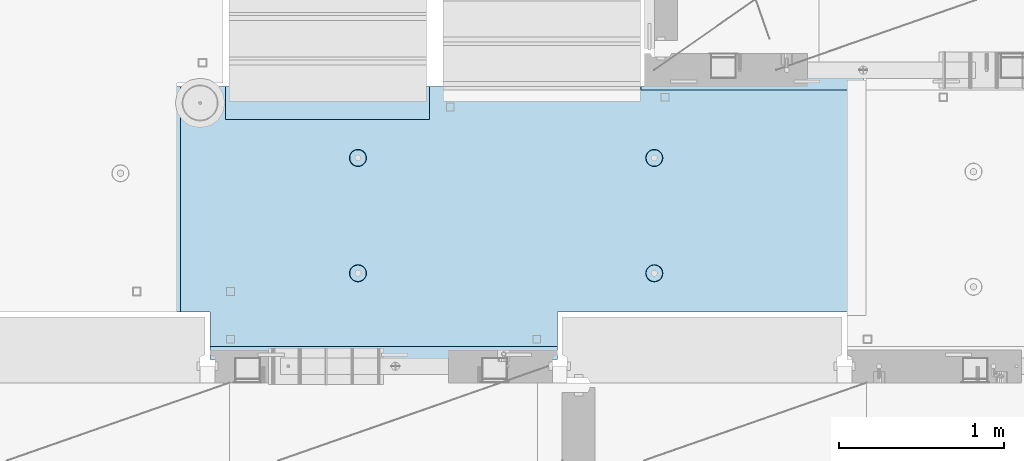
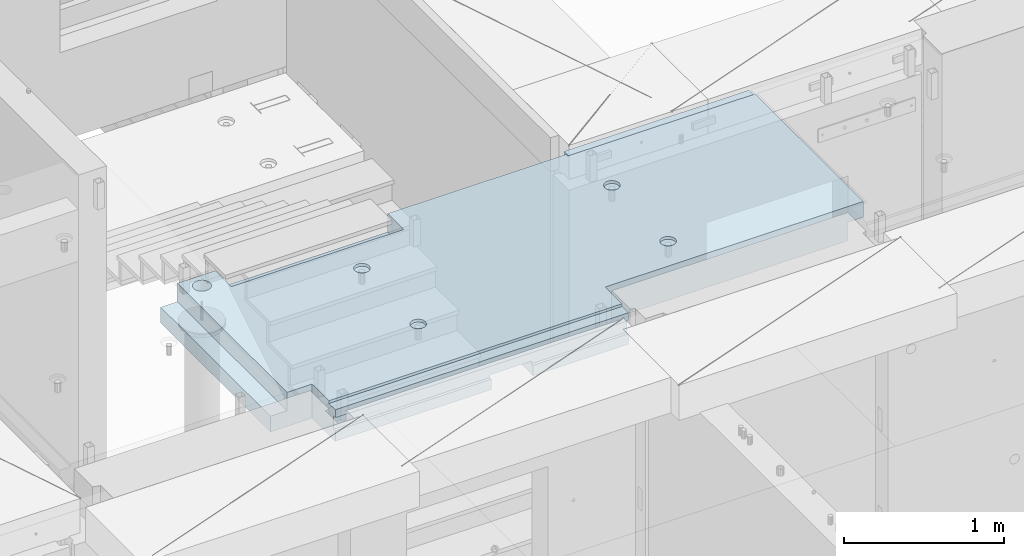
# One storey, part 206 of 352: 1 slab, 1 element without a shape of its own.
"""IFC2X3 building model written with IfcOpenShell, lengths in millimetres."""

from ifc_helpers import new_model, si_unit, frame, origin_with_axes, place, context, subcontext, project, spatial, faceted_brep, material, type_object, element, aggregate, save


model = new_model("IFC2X3")

# Units and contexts
model_context = context("Model", 3, precision=1e-05, world=origin_with_axes())
body_context = subcontext(model_context, "Body", "Model", "MODEL_VIEW")
ifc_project = project(units=[si_unit("LENGTHUNIT", "METRE", prefix="MILLI"), si_unit("AREAUNIT", "SQUARE_METRE"), si_unit("VOLUMEUNIT", "CUBIC_METRE"), si_unit("MASSUNIT", "GRAM", prefix="KILO"), si_unit("TIMEUNIT", "SECOND"), si_unit("PLANEANGLEUNIT", "RADIAN"), si_unit("SOLIDANGLEUNIT", "STERADIAN"), si_unit("THERMODYNAMICTEMPERATUREUNIT", "DEGREE_CELSIUS"), si_unit("LUMINOUSINTENSITYUNIT", "LUMEN")], contexts=[model_context])

# Site, building, storey
site_placement = place(None, origin_with_axes())
site = spatial("IfcSite", under=ifc_project, at=site_placement, CompositionType="ELEMENT")
building_placement = place(site_placement, origin_with_axes())
building = spatial("IfcBuilding", under=site, at=building_placement, CompositionType="ELEMENT")
storey_placement = place(building_placement, origin_with_axes())
storey = spatial("IfcBuildingStorey", under=building, at=storey_placement, Name="6", CompositionType="ELEMENT", Elevation=0.0)

# Assembly, slab
assembly_placement = place(storey_placement, origin_with_axes())
assembly = element("IfcElementAssembly", 1, at=assembly_placement, inside=storey, AssemblyPlace="NOTDEFINED", PredefinedType="REINFORCEMENT_UNIT")
ifc_material = material(Name="CONCRETE/C25/30")
slab_type = type_object("IfcSlabType", PredefinedType="NOTDEFINED")
slab_placement = place(assembly_placement, frame((23540.0159390845, 15510.0026483125, 99620.0), z_axis=(-0.999999999997437, -2.26400000064461e-06, 0.0), x_axis=(-2.2639999995273e-06, 0.999999999997437, 0.0)))
slab = element("IfcSlab", 2, at=slab_placement, type_object=slab_type, material=ifc_material, PredefinedType="FLOOR", context=body_context, shape_type="Brep", body=[
    faceted_brep([(-269.991394356101, 30.0, 2845.00213671412), (-79.9935682977648, 30.0, 2845.00213671301), (-79.9942474988402, 30.0, 2545.001661275), (-269.991475956112, 30.0, 2545.00209142873), (-79.9935682977648, 130.0, 2845.00213671301), (-269.991394356102, 50.0011356208415, 2845.00213671412), (-289.993566176285, 50.0011356208415, 2845.00213671423), (-289.993566176285, 130.0, 2845.00213671423), (-79.9942474988402, 130.0, 2545.001661275), (-289.994243058944, 130.0, 2545.00213671499), (-289.994243058944, 50.0011356208415, 2545.00213671499), (-269.991475956114, 50.0011356208415, 2545.00209142873), (250.667816023648, -110.0, 1223.00869116667), (264.606228919523, -110.0, 1230.11066726268), (275.667816023648, -110.0, 1241.1722543668), (282.76979211966, -110.0, 1255.11066726268), (285.216966304903, -110.0, 1270.56151698143), (282.769792119658, -110.0, 1286.01236670018), (275.667816023648, -110.0, 1299.95077959605), (264.606228919525, -110.0, 1311.01236670018), (250.667816023648, -110.0, 1318.11434279619), (235.216966304901, -110.0, 1320.56151698143), (219.766116586154, -110.0, 1318.11434279619), (205.827703690276, -110.0, 1311.01236670018), (194.766116586154, -110.0, 1299.95077959605), (187.664140490142, -110.0, 1286.01236670018), (185.216966304899, -110.0, 1270.56151698143), (187.664140490144, -110.0, 1255.11066726268), (194.766116586154, -110.0, 1241.1722543668), (205.827703690276, -110.0, 1230.11066726268), (219.766116586154, -110.0, 1223.00869116667), (235.216966304901, -110.0, 1220.56151698143), (251.370127374501, -130.0, 1220.84719908418), (235.216966304901, -130.0, 1218.2887897087), (265.942104492917, -130.0, 1228.27199227546), (277.506491010863, -130.0, 1239.83637879341), (284.931284202146, -130.0, 1254.40835591183), (287.489693577627, -130.0, 1270.56151698143), (284.931284202146, -130.0, 1286.71467805103), (277.506491010861, -130.0, 1301.28665516945), (265.942104492917, -130.0, 1312.85104168739), (251.370127374501, -130.0, 1320.27583487867), (235.216966304901, -130.0, 1322.83424425416), (219.063805235301, -130.0, 1320.27583487867), (204.491828116883, -130.0, 1312.85104168739), (192.927441598938, -130.0, 1301.28665516945), (185.502648407655, -130.0, 1286.71467805103), (182.944239032175, -130.0, 1270.56151698143), (185.502648407655, -130.0, 1254.40835591183), (192.92744159894, -130.0, 1239.83637879341), (204.491828116883, -130.0, 1228.27199227546), (219.063805235301, -130.0, 1220.84719908418), (1370.00988769532, 9.99999999994179, 4270.0029296875), (0.00703133410206647, 9.99999999994179, 4270.00341796875), (0.00594789032584231, 9.99999999994179, 4150.00335886026), (1370.00950450419, 9.99999999994179, 4150.0022190173), (1370.00988769532, 130.0, 4270.0029296875), (0.00703133410206647, 130.0, 4270.00341796875), (-289.995788574217, 50.0011356208415, 1860.01696777343), (-269.99166227209, 50.0011356208415, 1860.01689198933), (-289.995788574217, 130.0, 1860.01696777343), (1410.00403637765, -10.0000000000582, 115.00218916441), (-0.000334584017764428, -10.0000000000582, 115.003668258996), (-0.000334584015945438, 130.0, 115.003668258996), (1430.00436377147, 130.0, 115.002168181909), (1430.00283514406, 50.0011356437899, 115.002168184747), (1410.00403637764, 50.0011356208415, 115.002189163421), (1430.00659179688, 130.0, 1330.01220703125), (1370.00036621094, 130.0, 1330.01281738281), (1370.00036621094, -110.000000000073, 1330.01281738281), (1430.00659179688, -110.000000000073, 1330.01220703125), (1430.00656714066, -110.000000000073, 1.33804860524833e-08), (1370.00043098415, -110.000000000073, 1350.01312474485), (1349.99996962605, -110.000000000073, 1350.01302700259), (1350.00656713971, -110.000000000073, -1.09139364212751e-10), (1370.00043098415, -130.0, 1350.01312474485), (1349.99996962605, -130.000000000073, 1350.01302700259), (1350.00656713971, -130.0, -9.31322574615479e-10), (0.0, -130.0, -3.63797880709171e-12), (0.0, -10.0, 0.0), (1410.00416932017, -10.0000000000582, 1.69893610291183e-09), (1410.00416932017, -49.9988643791585, 5.89352566748858e-10), (1430.00416932019, -49.9988643791585, 2.83398549072444e-09), (1430.00277003324, 50.0011356208415, 1270.01537795496), (1430.00277003324, -49.9988643791585, 1270.01537795496), (1410.00277003325, 50.0011356208415, 1270.01535591496), (1410.00277003325, -49.9988643791585, 1270.01535591496), (-0.00148380931932479, -130.0, 510.016937255856), (-0.00148380931932479, 130.0, 510.016937255856), (0.00156440050341189, -130.0, 1860.01586914062), (0.00156440050341189, 130.0, 1860.01586914062), (-209.991713751984, -130.000000000058, 1860.01666468411), (-209.996345203012, -130.0, 3970.01713194715), (-209.996345203012, -110.000000000058, 3970.01713194715), (-209.991713751984, -110.000000000058, 1860.01666468411), (-289.991027832028, -110.000000000058, 3970.01733398437), (-289.995788574217, -110.000000000058, 1860.01696777343), (-289.991027832028, -49.9988643791585, 3970.01733398437), (-289.995788574217, -49.9988643791585, 1860.01696777343), (-269.99166227209, -49.9988643791585, 1860.01689198933), (-289.991027832028, 50.0011356208415, 3970.01733398437), (-289.991027832028, 130.0, 3970.01733398437), (-269.991088351981, 50.0011356208415, 3970.01728347186), (-269.991088351981, -49.9988643791585, 3970.01728347186), (0.00432284502676339, -130.0, 3970.0166015625), (0.00432284502676339, 130.0, 3970.0166015625), (0.00594789032584231, -130.0, 4150.00335886026), (1370.00950450419, -130.000000000058, 4150.0022190173), (1370.00860847197, -130.000000000058, 3875.01157736929), (1370.00860847198, 9.99639270307671, 3875.01157736929), (1370.00459258838, 9.99639270307671, 2635.00974632052), (1370.00459258838, -130.000000000029, 2635.00974632052), (1170.00318277859, 9.99639270307671, 3875.01203018158), (1170.00037541444, 9.99639270307671, 2635.01019913007), (1170.00318277859, -130.000000000029, 3875.01203018158), (1170.00037541444, -130.000000000029, 2635.01019913007), (920.332855772751, -110.0, 1318.11282667454), (906.394410719273, -110.0, 1311.01091369173), (895.332773528397, -110.0, 1299.94937667459), (888.230734319324, -110.0, 1286.01099593661), (885.78349017266, -110.0, 1270.56015729882), (888.230594396427, -110.0, 1255.10929649942), (895.332507379233, -110.0, 1241.17085144594), (906.394044396377, -110.0, 1230.10921425507), (920.332425134358, -110.0, 1223.00717504599), (935.783263772144, -110.0, 1220.55993089933), (951.234124571543, -110.0, 1223.0070351231), (965.172569625021, -110.0, 1230.10894810591), (976.234206815898, -110.0, 1241.17048512305), (983.33624602497, -110.0, 1255.10886586103), (985.783490171634, -110.0, 1270.55970449882), (983.336385947867, -110.0, 1286.01056529821), (976.234472965061, -110.0, 1299.94901035169), (965.172935947918, -110.0, 1311.01064754257), (951.234555209936, -110.0, 1318.11268675164), (935.783716572147, -110.0, 1320.5599308983), (951.936426135147, -130.0, 1220.84553986057), (935.783253481237, -130.0, 1218.28720362663), (966.508436872882, -130.0, 1228.27026706986), (978.072875754253, -130.0, 1239.83460122415), (985.497734927369, -130.0, 1254.40654472295), (988.05621744434, -130.0, 1270.55969420791), (985.497881210395, -130.0, 1286.71286686182), (978.073154001104, -130.0, 1301.28487759955), (966.508819846818, -130.0, 1312.84931648092), (951.936876348012, -130.0, 1320.27417565404), (935.783726863054, -130.0, 1322.83265817101), (919.630554209147, -130.0, 1320.27432193707), (905.058543471412, -130.0, 1312.84959472777), (893.494104590041, -130.0, 1301.28526057349), (886.069245416922, -130.0, 1286.71331707469), (883.510762899954, -130.0, 1270.56016758973), (886.069099133892, -130.0, 1254.40699493582), (893.49382634319, -130.0, 1239.83498419809), (905.058160497476, -130.0, 1228.27054531671), (919.630103996282, -130.0, 1220.84568614359), (920.336931380272, -110.0, 3118.29282666992), (906.398486326791, -110.0, 3111.19091368712), (895.336849135918, -110.0, 3100.12937666997), (888.234809926846, -110.0, 3086.19099593199), (885.787565780181, -110.0, 3070.7401572942), (888.234670003949, -110.0, 3055.28929649481), (895.336582986754, -110.0, 3041.35085144133), (906.398120003898, -110.0, 3030.28921425045), (920.33650074188, -110.0, 3023.18717504138), (935.787339379665, -110.0, 3020.73993089472), (951.238200179065, -110.0, 3023.18703511849), (965.176645232543, -110.0, 3030.28894810129), (976.238282423419, -110.0, 3041.35048511844), (983.340321632491, -110.0, 3055.28886585642), (985.787565779156, -110.0, 3070.7397044942), (983.340461555388, -110.0, 3086.1905652936), (976.238548572583, -110.0, 3100.12901034708), (965.177011555439, -110.0, 3111.19064753796), (951.238630817454, -110.0, 3118.29268674703), (935.787792179664, -110.0, 3120.73993089369), (951.940501742669, -130.000000000015, 3021.02553985595), (935.787329088758, -130.000000000015, 3018.46720362201), (966.512512480404, -130.000000000015, 3028.45026706525), (978.076951361778, -130.000000000015, 3040.01460121954), (985.50181053489, -130.000000000015, 3054.58654471834), (988.060293051862, -130.000000000015, 3070.73969420329), (985.501956817916, -130.000000000015, 3086.89286685721), (978.077229608625, -130.000000000015, 3101.46487759494), (966.51289545434, -130.000000000015, 3113.02931647631), (951.940951955534, -130.000000000015, 3120.45417564943), (935.787802470575, -130.000000000015, 3123.01265816639), (919.634629816665, -130.000000000015, 3120.45432193246), (905.062619078933, -130.000000000015, 3113.02959472316), (893.498180197559, -130.000000000015, 3101.46526056888), (886.07332102444, -130.000000000015, 3086.89331707007), (883.514838507475, -130.000000000015, 3070.74016758511), (886.073174741414, -130.000000000015, 3054.5869949312), (893.497901950712, -130.000000000015, 3040.01498419347), (905.062236104997, -130.000000000015, 3028.4505453121), (919.634179603803, -130.000000000015, 3021.02568613898), (250.671891631169, -110.0, 3023.18869116206), (264.610304527045, -110.0, 3030.29066725807), (275.671891631167, -110.0, 3041.35225436219), (282.773867727179, -110.0, 3055.29066725806), (285.221041912424, -110.0, 3070.74151697681), (282.773867727179, -110.0, 3086.19236669556), (275.671891631169, -110.0, 3100.13077959144), (264.610304527047, -110.0, 3111.19236669556), (250.671891631169, -110.0, 3118.29434279157), (235.221041912422, -110.0, 3120.74151697681), (219.770192193675, -110.0, 3118.29434279157), (205.831779297798, -110.0, 3111.19236669556), (194.770192193675, -110.0, 3100.13077959144), (187.668216097663, -110.0, 3086.19236669556), (185.22104191242, -110.0, 3070.74151697681), (187.668216097663, -110.0, 3055.29066725806), (194.770192193673, -110.0, 3041.35225436219), (205.831779297798, -110.0, 3030.29066725807), (219.770192193673, -110.0, 3023.18869116206), (235.221041912422, -110.0, 3020.74151697681), (251.374202982022, -130.0, 3021.02719907957), (235.221041912422, -130.0, 3018.46878970409), (265.946180100438, -130.0, 3028.45199227085), (277.510566618384, -130.0, 3040.0163787888), (284.935359809668, -130.0, 3054.58835590722), (287.493769185148, -130.0, 3070.74151697681), (284.935359809668, -130.0, 3086.89467804641), (277.510566618383, -130.0, 3101.46665516483), (265.946180100438, -130.0, 3113.03104168278), (251.374202982022, -130.0, 3120.45583487406), (235.22104191242, -130.0, 3123.01424424954), (219.067880842822, -130.0, 3120.45583487406), (204.495903724404, -130.0, 3113.03104168278), (192.93151720646, -130.0, 3101.46665516483), (185.506724015177, -130.0, 3086.89467804641), (182.948314639694, -130.0, 3070.74151697681), (185.506724015177, -130.0, 3054.58835590722), (192.93151720646, -130.0, 3040.0163787888), (204.495903724404, -130.0, 3028.45199227085), (219.06788084282, -130.0, 3021.02719907957), (1234.74413944682, -130.000000000029, 3981.4733287671), (1221.47026497402, -130.000000000029, 3994.74726334413), (1212.94793152671, -130.000000000029, 4011.47337811379), (1210.0113644813, -130.000000000029, 4030.01440442472), (1212.94801548044, -130.000000000029, 4048.55541743869), (1221.47042466352, -130.000000000029, 4065.28149361904), (1234.74435924055, -130.000000000029, 4078.55536809184), (1251.47047401021, -130.000000000029, 4087.07770153915), (1270.01150032114, -130.000000000029, 4090.01426858456), (1288.55251333511, -130.000000000029, 4087.07761758541), (1305.27858951547, -130.000000000029, 4078.55520840234), (1318.55246398826, -130.000000000029, 4065.28127382531), (1327.07479743557, -130.000000000029, 4048.55515905565), (1330.01136448099, -130.000000000029, 4030.01413274472), (1327.07471348184, -130.000000000029, 4011.47311973075), (1318.55230429877, -130.000000000029, 3994.74704355039), (1305.27836972173, -130.000000000029, 3981.4731690776), (1288.55225495208, -130.000000000029, 3972.95083563029), (1270.01122864114, -130.000000000029, 3970.01426858487), (1251.47021562717, -130.000000000029, 3972.95091958403), (1305.27836972173, 130.0, 3981.4731690776), (1288.55225495208, 130.0, 3972.95083563029), (1318.55230429877, 130.0, 3994.74704355039), (1327.07471348184, 130.0, 4011.47311973075), (1330.01136448099, 130.0, 4030.01413274472), (1327.07479743557, 130.0, 4048.55515905565), (1318.55246398826, 130.0, 4065.28127382531), (1305.27858951547, 130.0, 4078.55520840234), (1288.55251333511, 130.0, 4087.07761758541), (1270.01150032114, 130.0, 4090.01426858456), (1251.47047401021, 130.0, 4087.07770153915), (1234.74435924055, 130.0, 4078.55536809184), (1221.47042466352, 130.0, 4065.28149361904), (1212.94801548044, 130.0, 4048.55541743869), (1210.0113644813, 130.0, 4030.01440442472), (1212.94793152671, 130.0, 4011.47337811379), (1221.47026497402, 130.0, 3994.74726334413), (1234.74413944682, 130.0, 3981.4733287671), (1251.47021562717, 130.0, 3972.95091958403), (1270.01122864114, 130.0, 3970.01426858487)], [[[0, 1, 2, 3]], [[4, 1, 0, 5, 6, 7]], [[8, 2, 1, 4]], [[9, 10, 11, 3, 2, 8]], [[12, 13, 14, 15, 16, 17, 18, 19, 20, 21, 22, 23, 24, 25, 26, 27, 28, 29, 30, 31]], [[32, 12, 31, 33]], [[34, 13, 12, 32]], [[35, 14, 13, 34]], [[36, 15, 14, 35]], [[37, 16, 15, 36]], [[38, 17, 16, 37]], [[39, 18, 17, 38]], [[40, 19, 18, 39]], [[41, 20, 19, 40]], [[42, 21, 20, 41]], [[43, 22, 21, 42]], [[44, 23, 22, 43]], [[45, 24, 23, 44]], [[46, 25, 24, 45]], [[47, 26, 25, 46]], [[48, 27, 26, 47]], [[49, 28, 27, 48]], [[50, 29, 28, 49]], [[51, 30, 29, 50]], [[33, 31, 30, 51]], [[52, 53, 54, 55]], [[56, 57, 53, 52]], [[58, 59, 11, 10]], [[60, 58, 10, 9]], [[61, 62, 63, 64, 65, 66]], [[67, 68, 69, 70]], [[71, 70, 69, 72, 73, 74]], [[75, 76, 73, 72]], [[77, 74, 73, 76]], [[71, 74, 77, 78, 79, 80, 81, 82]], [[83, 65, 64, 67, 70, 71, 82, 84]], [[65, 83, 85, 66]], [[84, 86, 85, 83]], [[82, 81, 86, 84]], [[80, 61, 66, 85, 86, 81]], [[79, 62, 61, 80]], [[78, 87, 88, 63, 62, 79]], [[87, 89, 90, 88]], [[91, 92, 93, 94]], [[94, 93, 95, 96]], [[96, 95, 97, 98]], [[58, 60, 90, 89, 91, 94, 96, 98, 99, 59]], [[100, 101, 7, 6]], [[102, 100, 6, 5]], [[59, 99, 103, 102, 5, 0, 3, 11]], [[98, 97, 103, 99]], [[95, 93, 92, 104, 105, 101, 100, 102, 103, 97]], [[53, 57, 105, 104, 106, 54]], [[107, 55, 54, 106]], [[75, 72, 69, 68, 56, 52, 55, 107, 108, 109, 110, 111]], [[109, 112, 113, 110]], [[108, 114, 112, 109]], [[115, 113, 112, 114]], [[111, 110, 113, 115]], [[116, 117, 118, 119, 120, 121, 122, 123, 124, 125, 126, 127, 128, 129, 130, 131, 132, 133, 134, 135]], [[136, 126, 125, 137]], [[138, 127, 126, 136]], [[139, 128, 127, 138]], [[140, 129, 128, 139]], [[141, 130, 129, 140]], [[142, 131, 130, 141]], [[143, 132, 131, 142]], [[144, 133, 132, 143]], [[145, 134, 133, 144]], [[146, 135, 134, 145]], [[147, 116, 135, 146]], [[148, 117, 116, 147]], [[149, 118, 117, 148]], [[150, 119, 118, 149]], [[151, 120, 119, 150]], [[152, 121, 120, 151]], [[153, 122, 121, 152]], [[154, 123, 122, 153]], [[155, 124, 123, 154]], [[137, 125, 124, 155]], [[156, 157, 158, 159, 160, 161, 162, 163, 164, 165, 166, 167, 168, 169, 170, 171, 172, 173, 174, 175]], [[176, 166, 165, 177]], [[178, 167, 166, 176]], [[179, 168, 167, 178]], [[180, 169, 168, 179]], [[181, 170, 169, 180]], [[182, 171, 170, 181]], [[183, 172, 171, 182]], [[184, 173, 172, 183]], [[185, 174, 173, 184]], [[186, 175, 174, 185]], [[187, 156, 175, 186]], [[188, 157, 156, 187]], [[189, 158, 157, 188]], [[190, 159, 158, 189]], [[191, 160, 159, 190]], [[192, 161, 160, 191]], [[193, 162, 161, 192]], [[194, 163, 162, 193]], [[195, 164, 163, 194]], [[177, 165, 164, 195]], [[196, 197, 198, 199, 200, 201, 202, 203, 204, 205, 206, 207, 208, 209, 210, 211, 212, 213, 214, 215]], [[216, 196, 215, 217]], [[218, 197, 196, 216]], [[219, 198, 197, 218]], [[220, 199, 198, 219]], [[221, 200, 199, 220]], [[222, 201, 200, 221]], [[223, 202, 201, 222]], [[224, 203, 202, 223]], [[225, 204, 203, 224]], [[226, 205, 204, 225]], [[227, 206, 205, 226]], [[228, 207, 206, 227]], [[229, 208, 207, 228]], [[230, 209, 208, 229]], [[231, 210, 209, 230]], [[232, 211, 210, 231]], [[233, 212, 211, 232]], [[234, 213, 212, 233]], [[235, 214, 213, 234]], [[217, 215, 214, 235]], [[114, 108, 107, 106, 104, 92, 91, 89, 87, 78, 77, 76, 75, 111, 115], [234, 233, 232, 231, 230, 229, 228, 227, 226, 225, 224, 223, 222, 221, 220, 219, 218, 216, 217, 235], [194, 193, 192, 191, 190, 189, 188, 187, 186, 185, 184, 183, 182, 181, 180, 179, 178, 176, 177, 195], [154, 153, 152, 151, 150, 149, 148, 147, 146, 145, 144, 143, 142, 141, 140, 139, 138, 136, 137, 155], [50, 49, 48, 47, 46, 45, 44, 43, 42, 41, 40, 39, 38, 37, 36, 35, 34, 32, 33, 51], [236, 237, 238, 239, 240, 241, 242, 243, 244, 245, 246, 247, 248, 249, 250, 251, 252, 253, 254, 255]], [[252, 256, 257, 253]], [[251, 258, 256, 252]], [[250, 259, 258, 251]], [[249, 260, 259, 250]], [[248, 261, 260, 249]], [[247, 262, 261, 248]], [[246, 263, 262, 247]], [[245, 264, 263, 246]], [[244, 265, 264, 245]], [[243, 266, 265, 244]], [[242, 267, 266, 243]], [[241, 268, 267, 242]], [[240, 269, 268, 241]], [[239, 270, 269, 240]], [[238, 271, 270, 239]], [[237, 272, 271, 238]], [[236, 273, 272, 237]], [[255, 274, 273, 236]], [[254, 275, 274, 255]], [[253, 257, 275, 254]], [[7, 101, 105, 57, 56, 68, 67, 64, 63, 88, 90, 60, 9, 8, 4], [256, 258, 259, 260, 261, 262, 263, 264, 265, 266, 267, 268, 269, 270, 271, 272, 273, 274, 275, 257]]]),
])
aggregate(assembly, [slab])

save(model, "model.ifc")
